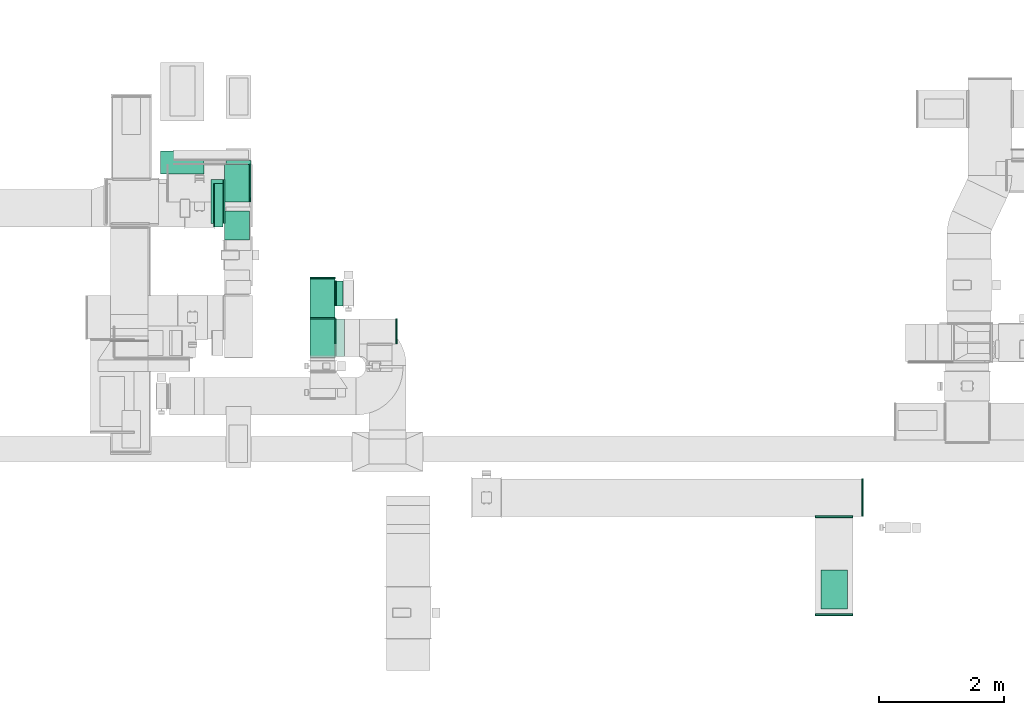
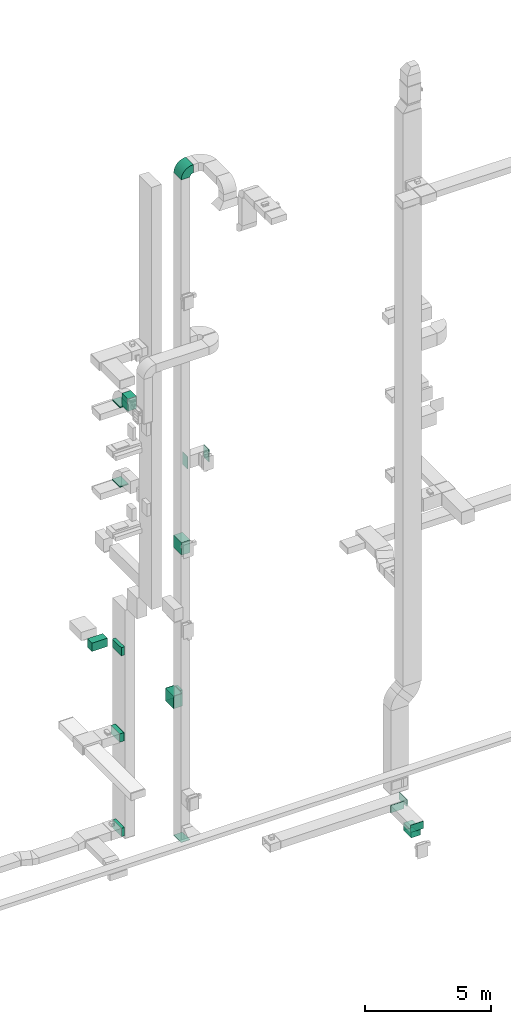
# One storey, part 14 of 29: 16 flow fittings, 10 flow segments, 1 flow terminal.
"""IFC2X3 building model written with IfcOpenShell, lengths in millimetres."""

import ifcopenshell
import ifcopenshell.guid

model = None  # the IFC model being written
_history = None  # IfcOwnerHistory: only IFC2X3 demands one
_inside = {}  # id of a spatial element -> (the spatial element, [elements in it])
_under = {}  # id of a project, library or spatial element -> (it, [spatial elements below it])
_declared = {}  # id of a project -> (the project, [libraries it declares])
_typed = {}  # id of a type object -> (the type object, [elements of that type])
_made_of = {}  # id of a material, layer set ... -> (it, [elements and type objects made of it])


def new_model(schema):
    """Start an empty IFC model of exactly this schema.

    Asked for "IFC4X3", IfcOpenShell would pick the latest addendum, in which some entities
    have other attributes; the version numbers below select the first issue.
    IFC2X3 requires an IfcOwnerHistory on every rooted entity: one is made here for all.
    """
    global model, _history
    if schema == "IFC4X3":
        model = ifcopenshell.file(schema_version=(4, 3, 0, 0))
    else:
        model = ifcopenshell.file(schema=schema)
    _inside.clear()
    _under.clear()
    _declared.clear()
    _typed.clear()
    _made_of.clear()
    _history = None
    if model.schema == "IFC2X3":
        org = make("IfcOrganization", Name="unknown")
        user = make(
            "IfcPersonAndOrganization",
            ThePerson=make("IfcPerson", FamilyName="unknown"),
            TheOrganization=org,
        )
        app = make(
            "IfcApplication",
            ApplicationDeveloper=org,
            Version="unknown",
            ApplicationFullName="unknown",
            ApplicationIdentifier="unknown",
        )
        _history = make(
            "IfcOwnerHistory",
            OwningUser=user,
            OwningApplication=app,
            ChangeAction="ADDED",
            CreationDate=0,
        )
    return model


def make(cls, **values):
    """One entity of the class cls with the attributes given. An attribute that is None is left unset."""
    return model.create_entity(
        cls, **{name: value for name, value in values.items() if value is not None}
    )


def entity(cls, *values):
    """Any entity or typed value of the class cls, its attributes in the order of the schema. None: left unset."""
    e = model.create_entity(cls)
    for i, value in enumerate(values):
        if value is not None:
            e[i] = value
    return e


def rooted(cls, **values):
    """An entity with a GlobalId (a new one), such as an element, a storey or a relation."""
    return make(cls, GlobalId=ifcopenshell.guid.new(), OwnerHistory=_history, **values)


def si_unit(unit_type, name, prefix=None):
    """IfcSIUnit, for example si_unit("LENGTHUNIT", "METRE", prefix="MILLI")."""
    return make("IfcSIUnit", UnitType=unit_type, Prefix=prefix, Name=name)


def converted_unit(unit_type, name, factor, base, dimensions=None, offset=None):
    """IfcConversionBasedUnit, such as the inch: factor (a typed value) times the base unit."""
    return make(
        "IfcConversionBasedUnit"
        if offset is None
        else "IfcConversionBasedUnitWithOffset",
        ConversionOffset=offset,
        Dimensions=None
        if dimensions is None
        else entity("IfcDimensionalExponents", *dimensions),
        UnitType=unit_type,
        Name=name,
        ConversionFactor=make(
            "IfcMeasureWithUnit", ValueComponent=factor, UnitComponent=base
        ),
    )


def derived_unit(unit_type, elements):
    """IfcDerivedUnit: a product of units, each with its exponent."""
    return make(
        "IfcDerivedUnit",
        Elements=[
            make("IfcDerivedUnitElement", Unit=unit, Exponent=power)
            for unit, power in elements
        ],
        UnitType=unit_type,
    )


def assignment(units):
    """IfcUnitAssignment: the units of a project."""
    return None if units is None else make("IfcUnitAssignment", Units=units)


def point(xyz):
    """IfcCartesianPoint."""
    return None if xyz is None else make("IfcCartesianPoint", Coordinates=xyz)


def direction(xyz):
    """IfcDirection."""
    return None if xyz is None else make("IfcDirection", DirectionRatios=xyz)


def frame(location, z_axis=None, x_axis=None):
    """IfcAxis2Placement3D, a coordinate frame: its origin and axes. An axis left out is left unset."""
    return make(
        "IfcAxis2Placement3D",
        Location=point(location),
        Axis=direction(z_axis),
        RefDirection=direction(x_axis),
    )


def frame_2d(location, x_axis=None):
    """IfcAxis2Placement2D, a coordinate frame in the plane: its origin and x axis."""
    return make(
        "IfcAxis2Placement2D", Location=point(location), RefDirection=direction(x_axis)
    )


def origin():
    """The frame at (0, 0, 0) with its axes left unset."""
    return frame((0.0, 0.0, 0.0))


def origin_2d_with_axis():
    """The frame at (0, 0) in the plane with the x axis (1, 0) written out."""
    return frame_2d((0.0, 0.0), x_axis=(1.0, 0.0))


def place(relative_to, where):
    """IfcLocalPlacement: puts the frame where relative to a parent placement (None: the world)."""
    return make(
        "IfcLocalPlacement", PlacementRelTo=relative_to, RelativePlacement=where
    )


def context(
    kind, dimensions, precision=None, world=None, true_north=None, identifier=None
):
    """IfcGeometricRepresentationContext, for example the 3D "Model" context."""
    return make(
        "IfcGeometricRepresentationContext",
        ContextIdentifier=identifier,
        ContextType=kind,
        CoordinateSpaceDimension=dimensions,
        Precision=precision,
        WorldCoordinateSystem=world,
        TrueNorth=true_north,
    )


def subcontext(parent, identifier, kind, view, scale=None):
    """IfcGeometricRepresentationSubContext, for example "Body" below "Model"."""
    return make(
        "IfcGeometricRepresentationSubContext",
        ContextIdentifier=identifier,
        ContextType=kind,
        ParentContext=parent,
        TargetScale=scale,
        TargetView=view,
    )


def project(units=None, contexts=None):
    """IfcProject with its units and contexts."""
    return rooted(
        "IfcProject",
        Name="project",
        RepresentationContexts=contexts,
        UnitsInContext=assignment(units),
    )


def spatial(cls, under=None, at=None, **own):
    """A site, building, storey or space (cls), placed at a placement, below another one or the project."""
    s = rooted(cls, ObjectPlacement=at, **own)
    if under is not None:
        _under.setdefault(under.id(), (under, []))[1].append(s)
    return s


def polyline(points):
    """IfcPolyline through the points."""
    return make("IfcPolyline", Points=[point(p) for p in points])


def circle_curve(where, radius):
    """IfcCircle in the frame where."""
    return make("IfcCircle", Position=where, Radius=radius)


def parameter(value):
    """IfcParameterValue: where a trimmed curve begins or ends, as a parameter of its basis curve."""
    return model.create_entity("IfcParameterValue", value)


def trimmed(basis, trim1, trim2, sense, master):
    """IfcTrimmedCurve: the piece of a basis curve between two trims."""
    return make(
        "IfcTrimmedCurve",
        BasisCurve=basis,
        Trim1=trim1,
        Trim2=trim2,
        SenseAgreement=sense,
        MasterRepresentation=master,
    )


def segment(curve, same_sense, transition):
    """IfcCompositeCurveSegment."""
    return make(
        "IfcCompositeCurveSegment",
        Transition=transition,
        SameSense=same_sense,
        ParentCurve=curve,
    )


def composite_curve(segments, self_intersect=None):
    """IfcCompositeCurve: segments joined end to end."""
    return make("IfcCompositeCurve", Segments=segments, SelfIntersect=self_intersect)


def profile(cls, at=None, kind="AREA", **sizes):
    """A parametric profile (cls). Its sizes go by their IFC names, for example OverallWidth=200.0."""
    return make(cls, ProfileType=kind, Position=at, **sizes)


def rectangle(**sizes):
    """IfcRectangleProfileDef."""
    return profile("IfcRectangleProfileDef", **sizes)


def outline(outer, holes=None, kind="AREA"):
    """IfcArbitraryClosedProfileDef: a profile drawn as a closed curve; with holes, ...WithVoids."""
    if holes is None:
        return make("IfcArbitraryClosedProfileDef", ProfileType=kind, OuterCurve=outer)
    return make(
        "IfcArbitraryProfileDefWithVoids",
        ProfileType=kind,
        OuterCurve=outer,
        InnerCurves=holes,
    )


def extrude(swept, where, along, depth):
    """IfcExtrudedAreaSolid: the profile swept, set in the frame where, extruded along a direction by depth."""
    return make(
        "IfcExtrudedAreaSolid",
        SweptArea=swept,
        Position=where,
        ExtrudedDirection=direction(along),
        Depth=depth,
    )


def shape(context_of_items, identifier, shape_type, items):
    """IfcShapeRepresentation: the items that make up one representation, for example the "Body"."""
    return make(
        "IfcShapeRepresentation",
        ContextOfItems=context_of_items,
        RepresentationIdentifier=identifier,
        RepresentationType=shape_type,
        Items=items,
    )


def source(mapping_origin, context_of_items, identifier, shape_type, items):
    """IfcRepresentationMap: a shape defined once, which mapped items show again and again."""
    return make(
        "IfcRepresentationMap",
        MappingOrigin=mapping_origin,
        MappedRepresentation=shape(context_of_items, identifier, shape_type, items),
    )


def transform(
    local_origin,
    x_axis=None,
    y_axis=None,
    z_axis=None,
    scale=None,
    scale2=None,
    scale3=None,
    uniform=True,
):
    """IfcCartesianTransformationOperator3D, or its non-uniform kind. x_axis, y_axis, z_axis: its Axis1, 2, 3."""
    if uniform:
        return make(
            "IfcCartesianTransformationOperator3D",
            Axis1=direction(x_axis),
            Axis2=direction(y_axis),
            LocalOrigin=point(local_origin),
            Scale=scale,
            Axis3=direction(z_axis),
        )
    return make(
        "IfcCartesianTransformationOperator3DnonUniform",
        Axis1=direction(x_axis),
        Axis2=direction(y_axis),
        LocalOrigin=point(local_origin),
        Scale=scale,
        Axis3=direction(z_axis),
        Scale2=scale2,
        Scale3=scale3,
    )


def mapped(mapping_source, mapping_target):
    """IfcMappedItem: shows the shape of a source again, moved by a transform."""
    return make(
        "IfcMappedItem", MappingSource=mapping_source, MappingTarget=mapping_target
    )


def material(Name=None, Category=None):
    """IfcMaterial."""
    return make("IfcMaterial", Name=Name, Category=Category)


def made_of(thing, what):
    """Note that an element or type object is made of a material, layer set ...; save() writes the relation."""
    if what is not None:
        _made_of.setdefault(what.id(), (what, []))[1].append(thing)
    return thing


def type_object(cls, material=None, **own):
    """A type object (cls), such as IfcWallType, which elements share."""
    return made_of(rooted(cls, **own), material)


def type_shapes(of_type, sources):
    """Give a type object the sources (RepresentationMaps) that its elements show as mapped items."""
    of_type.RepresentationMaps = sources


def element(
    cls,
    number,
    at=None,
    inside=None,
    cuts=None,
    type_object=None,
    material=None,
    context=None,
    identifier="Body",
    shape_type=None,
    held_by="IfcProductDefinitionShape",
    body=None,
    shapes=None,
    **own,
):
    """One element of the class cls, such as IfcWall. Its Tag is "e" and its number.

    at: its placement. inside: the storey or other place that contains it. cuts: it is an
    opening in that element (IfcRelVoidsElement). A single representation is given by context,
    identifier, shape_type and body (its items); several are given by shapes. held_by: the class
    of the entity that holds the representations. save() writes the other relations.
    """
    e = rooted(cls, Tag="e%d" % number, ObjectPlacement=at, **own)
    if body is not None:
        shapes = [shape(context, identifier, shape_type, body)]
    if shapes is not None:
        e.Representation = make(held_by, Representations=shapes)
    if inside is not None:
        _inside.setdefault(inside.id(), (inside, []))[1].append(e)
    if cuts is not None:
        rooted(
            "IfcRelVoidsElement", RelatingBuildingElement=cuts, RelatedOpeningElement=e
        )
    if type_object is not None:
        _typed.setdefault(type_object.id(), (type_object, []))[1].append(e)
    return made_of(e, material)


def aggregate(whole, parts):
    """IfcRelAggregates: a whole, such as a stair, and the parts it consists of."""
    return rooted("IfcRelAggregates", RelatingObject=whole, RelatedObjects=parts)


def save(model, path):
    """Write the relations noted so far, then the file.

    IfcRelAggregates (storeys below a building ...), IfcRelContainedInSpatialStructure (elements
    in a storey), IfcRelDefinesByType, IfcRelAssociatesMaterial and IfcRelDeclares: one each for
    every whole, place, type object, material and project.
    """
    for whole, parts in _under.values():
        aggregate(whole, parts)
    for where, things in _inside.values():
        rooted(
            "IfcRelContainedInSpatialStructure",
            RelatedElements=things,
            RelatingStructure=where,
        )
    for kind, things in _typed.values():
        rooted("IfcRelDefinesByType", RelatedObjects=things, RelatingType=kind)
    for what, things in _made_of.values():
        rooted("IfcRelAssociatesMaterial", RelatedObjects=things, RelatingMaterial=what)
    for by, libraries in _declared.values():
        rooted("IfcRelDeclares", RelatingContext=by, RelatedDefinitions=libraries)
    model.write(path)


model = new_model("IFC2X3")

# Units and contexts
model_context = context("Model", 3, precision=0.01, world=origin(), true_north=direction((6.12303176911189e-17, 1.0)))
body_context = subcontext(model_context, "Body", "Model", "MODEL_VIEW")
ifc_project = project(units=[si_unit("LENGTHUNIT", "METRE", prefix="MILLI"), si_unit("AREAUNIT", "SQUARE_METRE"), si_unit("VOLUMEUNIT", "CUBIC_METRE"), converted_unit("PLANEANGLEUNIT", "DEGREE", entity("IfcRatioMeasure", 0.0174532925199433), si_unit("PLANEANGLEUNIT", "RADIAN"), dimensions=[0, 0, 0, 0, 0, 0, 0]), si_unit("MASSUNIT", "GRAM", prefix="KILO"), derived_unit("MASSDENSITYUNIT", [(si_unit("MASSUNIT", "GRAM", prefix="KILO"), 1), (si_unit("LENGTHUNIT", "METRE"), -3)]), derived_unit("MOMENTOFINERTIAUNIT", [(si_unit("LENGTHUNIT", "METRE"), 4)]), si_unit("TIMEUNIT", "SECOND"), si_unit("FREQUENCYUNIT", "HERTZ"), si_unit("THERMODYNAMICTEMPERATUREUNIT", "DEGREE_CELSIUS"), derived_unit("THERMALTRANSMITTANCEUNIT", [(si_unit("MASSUNIT", "GRAM", prefix="KILO"), 1), (si_unit("THERMODYNAMICTEMPERATUREUNIT", "KELVIN"), -1), (si_unit("TIMEUNIT", "SECOND"), -3)]), derived_unit("VOLUMETRICFLOWRATEUNIT", [(si_unit("LENGTHUNIT", "METRE"), 3), (si_unit("TIMEUNIT", "SECOND"), -1)]), derived_unit("MASSFLOWRATEUNIT", [(si_unit("MASSUNIT", "GRAM", prefix="KILO"), 1), (si_unit("TIMEUNIT", "SECOND"), -1)]), derived_unit("ROTATIONALFREQUENCYUNIT", [(si_unit("TIMEUNIT", "SECOND"), -1)]), si_unit("ELECTRICCURRENTUNIT", "AMPERE"), si_unit("ELECTRICVOLTAGEUNIT", "VOLT"), si_unit("POWERUNIT", "WATT"), si_unit("FORCEUNIT", "NEWTON", prefix="KILO"), si_unit("ILLUMINANCEUNIT", "LUX"), si_unit("LUMINOUSFLUXUNIT", "LUMEN"), si_unit("LUMINOUSINTENSITYUNIT", "CANDELA"), derived_unit("USERDEFINED", [(si_unit("MASSUNIT", "GRAM", prefix="KILO"), -1), (si_unit("LENGTHUNIT", "METRE"), -2), (si_unit("TIMEUNIT", "SECOND"), 3), (si_unit("LUMINOUSFLUXUNIT", "LUMEN"), 1)]), derived_unit("LINEARVELOCITYUNIT", [(si_unit("LENGTHUNIT", "METRE"), 1), (si_unit("TIMEUNIT", "SECOND"), -1)]), si_unit("PRESSUREUNIT", "PASCAL"), derived_unit("USERDEFINED", [(si_unit("LENGTHUNIT", "METRE"), -2), (si_unit("MASSUNIT", "GRAM", prefix="KILO"), 1), (si_unit("TIMEUNIT", "SECOND"), -2)]), derived_unit("LINEARFORCEUNIT", [(si_unit("MASSUNIT", "GRAM", prefix="KILO"), 1), (si_unit("LENGTHUNIT", "METRE"), 1), (si_unit("TIMEUNIT", "SECOND"), -2), (si_unit("LENGTHUNIT", "METRE"), -1)]), derived_unit("PLANARFORCEUNIT", [(si_unit("MASSUNIT", "GRAM", prefix="KILO"), 1), (si_unit("LENGTHUNIT", "METRE"), 1), (si_unit("TIMEUNIT", "SECOND"), -2), (si_unit("LENGTHUNIT", "METRE"), -2)])], contexts=[model_context])

# Site, building, storey
site_placement = place(None, frame((0.0, -0.00077364408347762, 0.0)))
site = spatial("IfcSite", under=ifc_project, at=site_placement, CompositionType="ELEMENT")
building_placement = place(site_placement, origin())
building = spatial("IfcBuilding", under=site, at=building_placement, CompositionType="ELEMENT")
storey_placement = place(building_placement, origin())
storey = spatial("IfcBuildingStorey", under=building, at=storey_placement, CompositionType="ELEMENT", Elevation=0.0)

# Flow segments
duct_segment_type = type_object("IfcDuctSegmentType", PredefinedType="NOTDEFINED")
flow_segment_1_placement = place(storey_placement, frame((30120.0506788633, 12737.7217701701, 6700.0)))
element("IfcFlowSegment", 1, at=flow_segment_1_placement, inside=storey, type_object=duct_segment_type, context=body_context, shape_type="SweptSolid", body=[
    extrude(rectangle(XDim=154.950539610895, YDim=699.999999999999, at=frame_2d((0.0, 1.08002495835535e-12), x_axis=(1.0, 0.0))), frame((77.4752698054476, 350.0, 0.0), z_axis=(0.0, 0.0, 1.0), x_axis=(-1.0, 0.0, 0.0)), (0.0, 0.0, 1.0), 400.0),
])
flow_segment_2_placement = place(storey_placement, frame((29270.0506788633, 13587.7217701701, 6700.0)))
element("IfcFlowSegment", 2, at=flow_segment_2_placement, inside=storey, type_object=duct_segment_type, context=body_context, shape_type="SweptSolid", body=[
    extrude(rectangle(XDim=371.982987517842, YDim=700.000000000001, at=frame_2d((0.0, -2.1600499167107e-12), x_axis=(1.0, 0.0))), frame((350.0, 185.991493758921, 0.0), z_axis=(0.0, 0.0, 1.0), x_axis=(0.0, 1.0, 0.0)), (0.0, 0.0, 1.0), 400.0),
])
flow_segment_3_placement = place(storey_placement, frame((30080.1085349484, 12797.7217701701, 2500.0)))
element("IfcFlowSegment", 3, at=flow_segment_3_placement, inside=storey, type_object=duct_segment_type, context=body_context, shape_type="SweptSolid", body=[
    extrude(rectangle(XDim=194.892683525825, YDim=699.999999999999, at=frame_2d((2.16715534406831e-12, 0.0), x_axis=(1.0, 0.0))), frame((97.4463417629104, 350.0, 0.0), z_axis=(0.0, 0.0, 1.0), x_axis=(-1.0, 0.0, 0.0)), (0.0, 0.0, 1.0), 400.0),
])
flow_segment_4_placement = place(storey_placement, frame((30135.5441532585, 12739.7217701699, -2050.0)))
element("IfcFlowSegment", 4, at=flow_segment_4_placement, inside=storey, type_object=duct_segment_type, context=body_context, shape_type="SweptSolid", body=[
    extrude(rectangle(XDim=139.457065215677, YDim=699.999999999999, at=frame_2d((0.0, 1.08002495835535e-12), x_axis=(1.0, 0.0))), frame((69.7285326078383, 350.0, 0.0)), (0.0, 0.0, 1.0), 400.0),
])
flow_segment_5_placement = place(storey_placement, frame((31669.8749445684, 11285.0950531597, 4500.0)))
element("IfcFlowSegment", 5, at=flow_segment_5_placement, inside=storey, type_object=duct_segment_type, context=body_context, shape_type="SweptSolid", body=[
    extrude(rectangle(XDim=623.157125447534, YDim=400.0, at=frame_2d((0.0, -2.17426077142591e-12), x_axis=(1.0, 0.0))), frame((200.0, 311.578562723767, 0.0), z_axis=(0.0, 0.0, 1.0), x_axis=(0.0, 1.0, 0.0)), (0.0, 0.0, 1.0), 600.0),
])
flow_segment_6_placement = place(storey_placement, frame((32089.8445452176, 11475.2176763488, 4500.0)))
element("IfcFlowSegment", 6, at=flow_segment_6_placement, inside=storey, type_object=duct_segment_type, context=body_context, shape_type="SweptSolid", body=[
    extrude(rectangle(XDim=108.106004089515, YDim=400.0, at=origin_2d_with_axis()), frame((54.0834007711022, 200.008213570538, 0.0), z_axis=(0.0, 0.0, 1.0), x_axis=(0.999999988448493, 0.00015199675370579, 0.0)), (0.0, 0.0, 1.0), 600.000000000001),
])
flow_segment_7_placement = place(storey_placement, frame((39857.6700521892, 6610.94362200337, -1800.0)))
element("IfcFlowSegment", 7, at=flow_segment_7_placement, inside=storey, type_object=duct_segment_type, context=body_context, shape_type="SweptSolid", body=[
    extrude(rectangle(XDim=625.000000000001, YDim=424.999999999999, at=frame_2d((-5.40012479177676e-13, 0.0), x_axis=(1.0, 0.0))), frame((212.500000000004, 312.500000000007, 0.0), z_axis=(0.0, 0.0, 1.0), x_axis=(0.0, -1.0, 0.0)), (0.0, 0.0, 1.0), 330.000000000013),
])
flow_segment_8_placement = place(storey_placement, frame((30320.0012184742, 13206.024832867, 14520.0)))
element("IfcFlowSegment", 8, at=flow_segment_8_placement, inside=storey, type_object=duct_segment_type, context=body_context, shape_type="SweptSolid", body=[
    extrude(rectangle(XDim=600.000000000002, YDim=400.0, at=frame_2d((-1.08002495835535e-12, 0.0), x_axis=(1.0, 0.0))), frame((200.0, 300.0, 0.0), z_axis=(0.0, 0.0, 1.0), x_axis=(0.0, -1.0, 0.0)), (0.0, 0.0, 1.0), 30.000000000043),
])
flow_segment_9_placement = place(storey_placement, frame((30295.0012184743, 12526.340949735, 18600.0)))
element("IfcFlowSegment", 9, at=flow_segment_9_placement, inside=storey, type_object=duct_segment_type, context=body_context, shape_type="SweptSolid", body=[
    extrude(rectangle(XDim=466.041082953118, YDim=400.0, at=frame_2d((0.0, -2.17426077142591e-12), x_axis=(1.0, 0.0))), frame((200.0, 233.020541476559, 0.0), z_axis=(0.0, 0.0, 1.0), x_axis=(0.0, 1.0, 0.0)), (0.0, 0.0, 1.0), 600.000000000002),
])
flow_segment_10_placement = place(storey_placement, frame((30295.0012184743, 13142.3820326881, 18420.0)))
element("IfcFlowSegment", 10, at=flow_segment_10_placement, inside=storey, type_object=duct_segment_type, context=body_context, shape_type="SweptSolid", body=[
    extrude(rectangle(XDim=400.000000000004, YDim=600.0, at=frame_2d((4.33431068813661e-12, -1.08002495835535e-12), x_axis=(1.0, 0.0))), frame((200.0, 300.0, 0.0)), (0.0, 0.0, 1.0), 29.9999999999975),
])

# Flow fittings
ifc_material_1 = material()
duct_fitting_type_1 = type_object("IfcDuctFittingType", PredefinedType="NOTDEFINED", material=ifc_material_1)
shared_shape_1 = source(origin(), body_context, "Body", "SweptSolid", [
    extrude(rectangle(XDim=26.0960000000006, YDim=400.0, at=frame_2d((-3.10862446895044e-13, -1.4210854715202e-13), x_axis=(1.0, 0.0))), frame((6.95199999999999, 0.0, -350.0)), (0.0, 0.0, 1.0), 700.0),
])
type_shapes(duct_fitting_type_1, [shared_shape_1])
flow_fitting_1_placement = place(storey_placement, frame((30295.0012184742, 13147.7217701701, 2700.0), z_axis=(0.0, 1.0, 0.0), x_axis=(-1.0, 0.0, 0.0)))
element("IfcFlowFitting", 11, at=flow_fitting_1_placement, inside=storey, type_object=duct_fitting_type_1, material=ifc_material_1, context=body_context, shape_type="MappedRepresentation", body=[
    mapped(shared_shape_1, transform((0.0, 0.0, 0.0), scale=1.0)),
])
duct_fitting_type_2 = type_object("IfcDuctFittingType", PredefinedType="NOTDEFINED", material=ifc_material_1)
shared_shape_2 = source(origin(), body_context, "Body", "SweptSolid", [
    extrude(rectangle(XDim=26.0960000000009, YDim=600.0, at=frame_2d((-4.66293670342566e-13, -1.4210854715202e-13), x_axis=(1.0, 0.0))), frame((6.95199999999999, 0.0, -200.0)), (0.0, 0.0, 1.0), 400.0),
])
type_shapes(duct_fitting_type_2, [shared_shape_2])
for number, where, z_axis, x_axis in (
    (12, (32069.8749445684, 11065.0950531597, 16500.0), (0.0, -1.0, 0.0), (1.0, 0.0, 0.0)),
    (13, (31869.8749445684, 11265.0950531597, 4800.0), (1.0, 0.0, 0.0), (0.0, 1.0, 0.0)),
):
    element("IfcFlowFitting", number, at=place(storey_placement, frame(where, z_axis=z_axis, x_axis=x_axis)), inside=storey, type_object=duct_fitting_type_2, material=ifc_material_1, context=body_context, shape_type="MappedRepresentation", body=[
        mapped(shared_shape_2, transform((0.0, 0.0, 0.0), scale=1.0)),
    ])
duct_fitting_type_3 = type_object("IfcDuctFittingType", PredefinedType="NOTDEFINED", material=ifc_material_1)
shared_shape_3 = source(origin(), body_context, "Body", "SweptSolid", [
    extrude(rectangle(XDim=24.9999999999999, YDim=400.0, at=frame_2d((-1.63424829224823e-13, 0.0), x_axis=(1.0, 0.0))), frame((12.5000000000061, 0.0, -300.0)), (0.0, 0.0, 1.0), 600.0),
])
type_shapes(duct_fitting_type_3, [shared_shape_3])
flow_fitting_2_placement = place(storey_placement, frame((33044.0299588269, 11065.0950531597, 16500.0)))
element("IfcFlowFitting", 14, at=flow_fitting_2_placement, inside=storey, type_object=duct_fitting_type_3, material=ifc_material_1, context=body_context, shape_type="MappedRepresentation", body=[
    mapped(shared_shape_3, transform((0.0, 0.0, 0.0), scale=1.0)),
])
flow_fitting_3_placement = place(storey_placement, frame((31869.8749445683, 11908.2521786072, 4800.0), z_axis=(0.0, 0.0, 1.0), x_axis=(0.0, 1.0, 0.0)))
element("IfcFlowFitting", 15, at=flow_fitting_3_placement, inside=storey, type_object=duct_fitting_type_3, material=ifc_material_1, context=body_context, shape_type="MappedRepresentation", body=[
    mapped(shared_shape_3, transform((0.0, 0.0, 0.0), scale=1.0)),
])
duct_fitting_type_4 = type_object("IfcDuctFittingType", PredefinedType="NOTDEFINED", material=ifc_material_1)
shared_shape_4 = source(origin(), body_context, "Body", "SweptSolid", [
    extrude(rectangle(XDim=24.9999999999999, YDim=600.0, at=frame_2d((-2.46913600676635e-13, 0.0), x_axis=(1.0, 0.0))), frame((12.500000000006, 0.0, -150.0)), (0.0, 0.0, 1.0), 300.0),
])
type_shapes(duct_fitting_type_4, [shared_shape_4])
flow_fitting_4_placement = place(storey_placement, frame((30693.9378229565, 13442.3820326881, 18250.0)))
element("IfcFlowFitting", 16, at=flow_fitting_4_placement, inside=storey, type_object=duct_fitting_type_4, material=ifc_material_1, context=body_context, shape_type="MappedRepresentation", body=[
    mapped(shared_shape_4, transform((0.0, 0.0, 0.0), scale=1.0)),
])
duct_fitting_type_5 = type_object("IfcDuctFittingType", PredefinedType="NOTDEFINED", material=ifc_material_1)
shared_shape_5 = source(origin(), body_context, "Body", "SweptSolid", [
    extrude(rectangle(XDim=24.9999999999999, YDim=600.0, at=frame_2d((-2.46913600676635e-13, 0.0), x_axis=(1.0, 0.0))), frame((12.500000000006, 0.0, -200.0)), (0.0, 0.0, 1.0), 400.0),
])
type_shapes(duct_fitting_type_5, [shared_shape_5])
flow_fitting_5_placement = place(storey_placement, frame((31869.8749445684, 10965.0950531597, -1605.0), z_axis=(1.0, 0.0, 0.0), x_axis=(0.0, 0.0, -1.0)))
element("IfcFlowFitting", 17, at=flow_fitting_5_placement, inside=storey, type_object=duct_fitting_type_5, material=ifc_material_1, context=body_context, shape_type="MappedRepresentation", body=[
    mapped(shared_shape_5, transform((0.0, 0.0, 0.0), scale=1.0)),
])
duct_fitting_type_6 = type_object("IfcDuctFittingType", PredefinedType="NOTDEFINED", material=ifc_material_1)
shared_shape_6 = source(origin(), body_context, "Body", "SweptSolid", [
    extrude(rectangle(XDim=26.0960000000093, YDim=400.0, at=frame_2d((-3.10862446895044e-13, -1.4210854715202e-13), x_axis=(1.0, 0.0))), frame((6.95199999999999, 0.0, -300.0)), (0.0, 0.0, 1.0), 600.0),
])
type_shapes(duct_fitting_type_6, [shared_shape_6])
flow_fitting_6_placement = place(storey_placement, frame((32069.8749445684, 11675.2176740385, 4800.0), z_axis=(0.0, 0.0, -1.0), x_axis=(1.0, 0.0, 0.0)))
element("IfcFlowFitting", 18, at=flow_fitting_6_placement, inside=storey, type_object=duct_fitting_type_6, material=ifc_material_1, context=body_context, shape_type="MappedRepresentation", body=[
    mapped(shared_shape_6, transform((0.0, 0.0, 0.0), scale=1.0)),
])
duct_fitting_type_7 = type_object("IfcDuctFittingType", PredefinedType="NOTDEFINED", material=ifc_material_1)
shared_shape_7 = source(origin(), body_context, "Body", "SweptSolid", [
    extrude(outline(composite_curve([segment(polyline([(-375.0, -175.0), (25.0, -175.0)]), True, "CONTINUOUS"), segment(trimmed(circle_curve(frame_2d((175.0, -175.0), x_axis=(0.0, 1.0)), 150.0), [parameter(0.0)], [parameter(90.0000000000001)], True, "PARAMETER"), False, "CONTINUOUS"), segment(polyline([(175.0, -25.0), (175.0, 375.0)]), True, "CONTINUOUS"), segment(trimmed(circle_curve(frame_2d((175.0, -175.0), x_axis=(0.0, 1.0)), 550.0), [parameter(0.0)], [parameter(90.0)], True, "PARAMETER"), True, "CONTINUOUS")], self_intersect=False)), frame((-175.0, 175.0, -300.0), z_axis=(0.0, 0.0, 1.0), x_axis=(-1.0, 0.0, 0.0)), (0.0, 0.0, 1.0), 600.0),
])
type_shapes(duct_fitting_type_7, [shared_shape_7])
flow_fitting_7_placement = place(storey_placement, frame((31869.8749445684, 10965.0950531597, 30805.4908940358), z_axis=(0.0, -1.0, 0.0), x_axis=(-1.0, 0.0, 0.0)))
element("IfcFlowFitting", 19, at=flow_fitting_7_placement, inside=storey, type_object=duct_fitting_type_7, material=ifc_material_1, context=body_context, shape_type="MappedRepresentation", body=[
    mapped(shared_shape_7, transform((0.0, 0.0, 0.0), scale=1.0)),
])
duct_fitting_type_8 = type_object("IfcDuctFittingType", PredefinedType="NOTDEFINED", material=ifc_material_1)
shared_shape_8 = source(origin(), body_context, "Body", "SweptSolid", [
    extrude(rectangle(XDim=24.9999999999999, YDim=600.0, at=frame_2d((-2.46913600676635e-13, 0.0), x_axis=(1.0, 0.0))), frame((12.500000000006, 0.0, -175.0)), (0.0, 0.0, 1.0), 350.0),
])
type_shapes(duct_fitting_type_8, [shared_shape_8])
flow_fitting_8_placement = place(storey_placement, frame((40515.3986486254, 8400.00003916104, -1250.0)))
element("IfcFlowFitting", 20, at=flow_fitting_8_placement, inside=storey, type_object=duct_fitting_type_8, material=ifc_material_1, context=body_context, shape_type="MappedRepresentation", body=[
    mapped(shared_shape_8, transform((0.0, 0.0, 0.0), scale=1.0)),
])
flow_fitting_9_placement = place(storey_placement, frame((40070.1700521892, 6532.86534181993, -1275.0), z_axis=(0.0, 0.0, 1.0), x_axis=(0.0, -1.0, 0.0)))
element("IfcFlowFitting", 21, at=flow_fitting_9_placement, inside=storey, type_object=duct_fitting_type_8, material=ifc_material_1, context=body_context, shape_type="MappedRepresentation", body=[
    mapped(shared_shape_8, transform((0.0, 0.0, 0.0), scale=1.0)),
])

# Flow terminal
ifc_material_2 = material()
air_terminal_type = type_object("IfcAirTerminalType", PredefinedType="NOTDEFINED", material=ifc_material_2)
shared_shape_9 = source(origin(), body_context, "Body", "SweptSolid", [
    extrude(rectangle(XDim=4.0, YDim=624.999999999999, at=origin_2d_with_axis()), frame((0.0, -2.0, -212.500000000002), z_axis=(0.0, 0.0, 1.0), x_axis=(0.0, 1.0, 0.0)), (0.0, 0.0, 1.0), 425.000000000005),
])
type_shapes(air_terminal_type, [shared_shape_9])
flow_terminal_placement = place(storey_placement, frame((40070.1700521892, 6923.44362200337, -1800.0), z_axis=(1.0, 0.0, 0.0), x_axis=(0.0, 1.0, 0.0)))
element("IfcFlowTerminal", 22, at=flow_terminal_placement, inside=storey, type_object=air_terminal_type, material=ifc_material_2, context=body_context, shape_type="MappedRepresentation", body=[
    mapped(shared_shape_9, transform((0.0, 0.0, 0.0), scale=1.0)),
])

# Flow fittings
duct_fitting_type_9 = type_object("IfcDuctFittingType", PredefinedType="NOTDEFINED", material=ifc_material_1)
shared_shape_10 = source(origin(), body_context, "Body", "SweptSolid", [
    extrude(rectangle(XDim=425.0, YDim=26.0960000000038, at=origin_2d_with_axis()), frame((6.95199999999999, 0.0, -312.5), z_axis=(0.0, 0.0, 1.0), x_axis=(0.0, -1.0, 0.0)), (0.0, 0.0, 1.0), 625.0),
])
type_shapes(duct_fitting_type_9, [shared_shape_10])
flow_fitting_10_placement = place(storey_placement, frame((40070.1700521892, 6923.44362200337, -1450.0), z_axis=(0.0, -1.0, 0.0), x_axis=(0.0, 0.0, -1.0)))
element("IfcFlowFitting", 23, at=flow_fitting_10_placement, inside=storey, type_object=duct_fitting_type_9, material=ifc_material_1, context=body_context, shape_type="MappedRepresentation", body=[
    mapped(shared_shape_10, transform((0.0, 0.0, 0.0), scale=1.0)),
])
duct_fitting_type_10 = type_object("IfcDuctFittingType", PredefinedType="NOTDEFINED", material=ifc_material_1)
shared_shape_11 = source(origin(), body_context, "Body", "SweptSolid", [
    extrude(rectangle(XDim=600.0, YDim=626.049132676807, at=origin_2d_with_axis()), frame((-293.024566338403, 0.0, -200.0), z_axis=(0.0, 0.0, 1.0), x_axis=(0.0, -1.0, 0.0)), (0.0, 0.0, 1.0), 400.0),
])
type_shapes(duct_fitting_type_10, [shared_shape_11])
flow_fitting_11_placement = place(storey_placement, frame((31869.8749445684, 10665.0950531597, 12600.0), z_axis=(-0.999999972523857, -0.000234419037975662, 0.0), x_axis=(0.000234419037975662, -0.999999972523857, 0.0)))
element("IfcFlowFitting", 24, at=flow_fitting_11_placement, inside=storey, type_object=duct_fitting_type_10, material=ifc_material_1, context=body_context, shape_type="MappedRepresentation", body=[
    mapped(shared_shape_11, transform((0.0, 0.0, 0.0), scale=1.0)),
])
duct_fitting_type_11 = type_object("IfcDuctFittingType", PredefinedType="NOTDEFINED", material=ifc_material_1)
shared_shape_12 = source(origin(), body_context, "Body", "SweptSolid", [
    extrude(rectangle(XDim=400.0, YDim=26.0960000000065, at=origin_2d_with_axis()), frame((6.95199999999891, 0.0, -300.0), z_axis=(0.0, 0.0, 1.0), x_axis=(0.0, -1.0, 0.0)), (0.0, 0.0, 1.0), 600.0),
])
type_shapes(duct_fitting_type_11, [shared_shape_12])
for number, where, z_axis, x_axis in (
    (25, (30520.0012184742, 13506.024832867, 14500.0), (0.0, -1.0, 0.0), (0.0, 0.0, 1.0)),
    (26, (30495.0012184743, 13442.3820326881, 18400.0), (0.0, 1.0, 0.0), (0.0, 0.0, 1.0)),
):
    element("IfcFlowFitting", number, at=place(storey_placement, frame(where, z_axis=z_axis, x_axis=x_axis)), inside=storey, type_object=duct_fitting_type_11, material=ifc_material_1, context=body_context, shape_type="MappedRepresentation", body=[
        mapped(shared_shape_12, transform((0.0, 0.0, 0.0), scale=1.0)),
    ])
duct_fitting_type_12 = type_object("IfcDuctFittingType", PredefinedType="NOTDEFINED", material=ifc_material_1)
shared_shape_13 = source(origin(), body_context, "Body", "SweptSolid", [
    extrude(rectangle(XDim=26.0960000000009, YDim=600.0, at=frame_2d((-4.66293670342566e-13, -1.4210854715202e-13), x_axis=(1.0, 0.0))), frame((6.95199999999999, 0.0, -175.0)), (0.0, 0.0, 1.0), 350.0),
])
type_shapes(duct_fitting_type_12, [shared_shape_13])
flow_fitting_12_placement = place(storey_placement, frame((40070.1700521892, 8100.00003916102, -1275.0), z_axis=(0.0, 0.0, -1.0), x_axis=(0.0, -1.0, 0.0)))
element("IfcFlowFitting", 27, at=flow_fitting_12_placement, inside=storey, type_object=duct_fitting_type_12, material=ifc_material_1, context=body_context, shape_type="MappedRepresentation", body=[
    mapped(shared_shape_13, transform((0.0, 0.0, 0.0), scale=1.0)),
])

save(model, "model.ifc")
